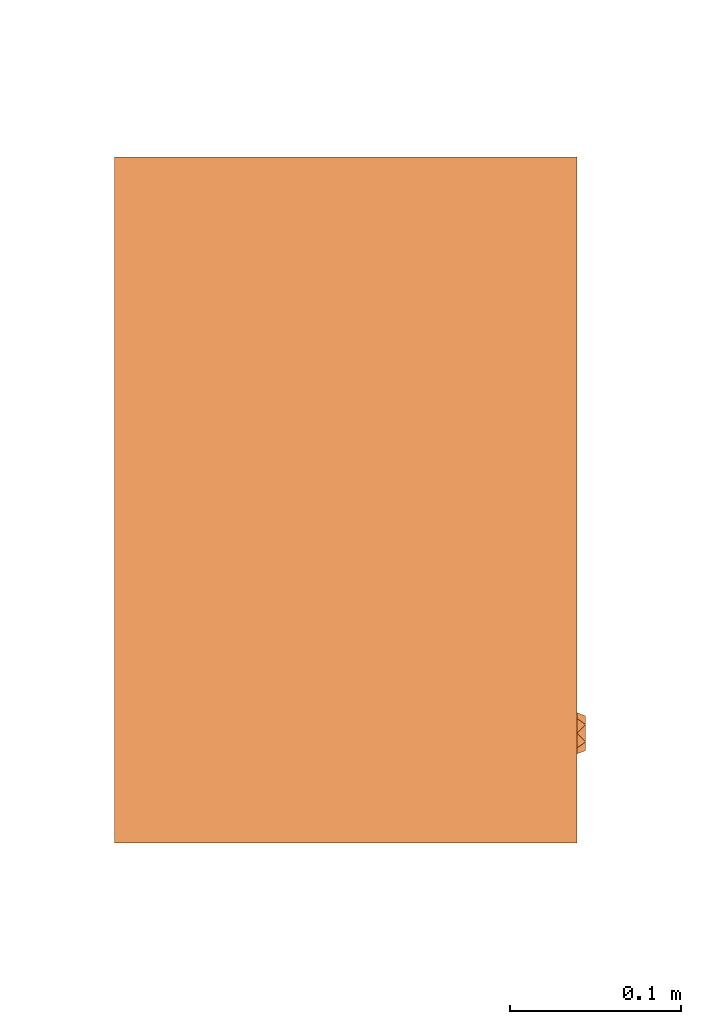
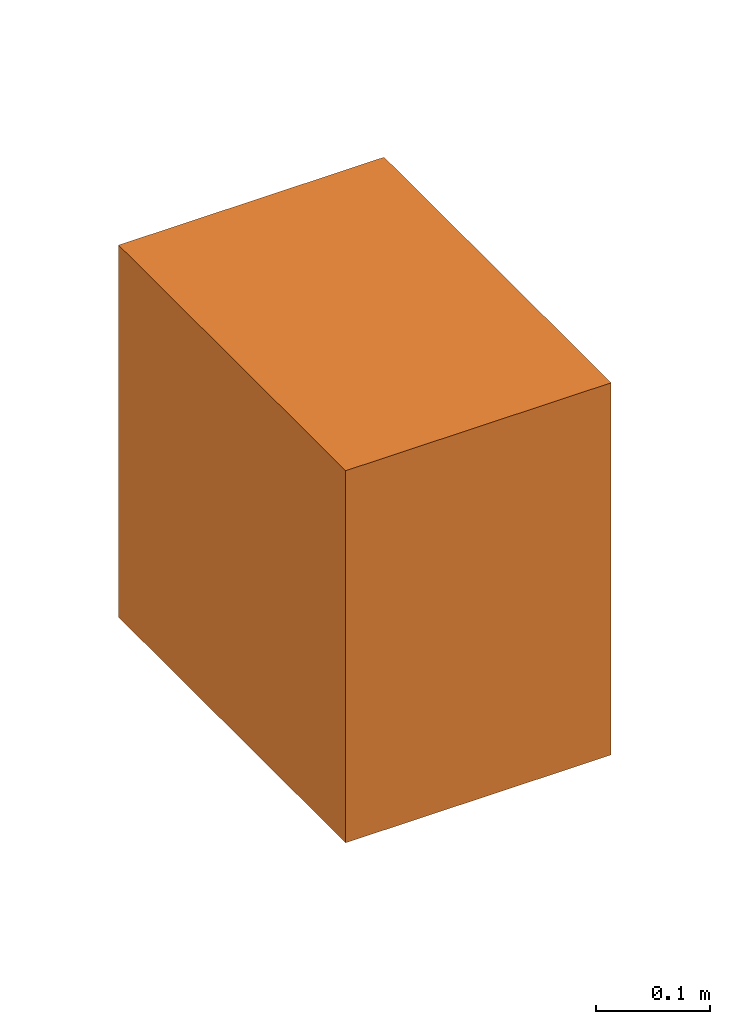
# One storey, part 3 of 3: 1 proxy.
"""IFC2X3 building model written with IfcOpenShell, lengths in millimetres."""

from ifc_helpers import new_model, entity, si_unit, converted_unit, derived_unit, direction, frame, origin, place, context, subcontext, project, spatial, faceted_brep, source, transform, mapped, material, material_list, type_object, type_shapes, element, save


model = new_model("IFC2X3")

# Units and contexts
model_context = context("Model", 3, precision=0.01, world=origin(), true_north=direction((6.12303176911189e-17, 1.0)))
body_context = subcontext(model_context, "Body", "Model", "MODEL_VIEW")
ifc_project = project(units=[si_unit("LENGTHUNIT", "METRE", prefix="MILLI"), si_unit("AREAUNIT", "SQUARE_METRE"), si_unit("VOLUMEUNIT", "CUBIC_METRE"), converted_unit("PLANEANGLEUNIT", "DEGREE", entity("IfcRatioMeasure", 0.0174532925199433), si_unit("PLANEANGLEUNIT", "RADIAN"), dimensions=[0, 0, 0, 0, 0, 0, 0]), si_unit("MASSUNIT", "GRAM", prefix="KILO"), derived_unit("MASSDENSITYUNIT", [(si_unit("MASSUNIT", "GRAM", prefix="KILO"), 1), (si_unit("LENGTHUNIT", "METRE"), -3)]), derived_unit("MOMENTOFINERTIAUNIT", [(si_unit("LENGTHUNIT", "METRE"), 4)]), si_unit("TIMEUNIT", "SECOND"), si_unit("FREQUENCYUNIT", "HERTZ"), si_unit("THERMODYNAMICTEMPERATUREUNIT", "DEGREE_CELSIUS"), derived_unit("THERMALTRANSMITTANCEUNIT", [(si_unit("MASSUNIT", "GRAM", prefix="KILO"), 1), (si_unit("THERMODYNAMICTEMPERATUREUNIT", "KELVIN"), -1), (si_unit("TIMEUNIT", "SECOND"), -3)]), derived_unit("VOLUMETRICFLOWRATEUNIT", [(si_unit("LENGTHUNIT", "METRE"), 3), (si_unit("TIMEUNIT", "SECOND"), -1)]), derived_unit("MASSFLOWRATEUNIT", [(si_unit("MASSUNIT", "GRAM", prefix="KILO"), 1), (si_unit("TIMEUNIT", "SECOND"), -1)]), derived_unit("ROTATIONALFREQUENCYUNIT", [(si_unit("TIMEUNIT", "SECOND"), -1)]), si_unit("ELECTRICCURRENTUNIT", "AMPERE"), si_unit("ELECTRICVOLTAGEUNIT", "VOLT"), si_unit("POWERUNIT", "WATT"), si_unit("FORCEUNIT", "NEWTON", prefix="KILO"), si_unit("ILLUMINANCEUNIT", "LUX"), si_unit("LUMINOUSFLUXUNIT", "LUMEN"), si_unit("LUMINOUSINTENSITYUNIT", "CANDELA"), derived_unit("USERDEFINED", [(si_unit("MASSUNIT", "GRAM", prefix="KILO"), -1), (si_unit("LENGTHUNIT", "METRE"), -2), (si_unit("TIMEUNIT", "SECOND"), 3), (si_unit("LUMINOUSFLUXUNIT", "LUMEN"), 1)]), derived_unit("LINEARVELOCITYUNIT", [(si_unit("LENGTHUNIT", "METRE"), 1), (si_unit("TIMEUNIT", "SECOND"), -1)]), si_unit("PRESSUREUNIT", "PASCAL"), derived_unit("USERDEFINED", [(si_unit("LENGTHUNIT", "METRE"), -2), (si_unit("MASSUNIT", "GRAM", prefix="KILO"), 1), (si_unit("TIMEUNIT", "SECOND"), -2)]), derived_unit("LINEARFORCEUNIT", [(si_unit("MASSUNIT", "GRAM", prefix="KILO"), 1), (si_unit("LENGTHUNIT", "METRE"), 1), (si_unit("TIMEUNIT", "SECOND"), -2), (si_unit("LENGTHUNIT", "METRE"), -1)]), derived_unit("PLANARFORCEUNIT", [(si_unit("MASSUNIT", "GRAM", prefix="KILO"), 1), (si_unit("LENGTHUNIT", "METRE"), 1), (si_unit("TIMEUNIT", "SECOND"), -2), (si_unit("LENGTHUNIT", "METRE"), -2)])], contexts=[model_context])

# Site, building, storey
site_placement = place(None, frame((0.0, 2493.83037508239, 0.0)))
site = spatial("IfcSite", under=ifc_project, at=site_placement, CompositionType="ELEMENT")
building_placement = place(site_placement, origin())
building = spatial("IfcBuilding", under=site, at=building_placement, CompositionType="ELEMENT")
storey_placement = place(building_placement, frame((0.0, 0.0, -4200.0)))
storey = spatial("IfcBuildingStorey", under=building, at=storey_placement, CompositionType="ELEMENT", Elevation=-4200.0)

# Proxy
ifc_material_1 = material()
ifc_material_2 = material(Name="RBZ_")
ifc_material_list = material_list([ifc_material_1, ifc_material_2])
building_element_proxy_type = type_object("IfcBuildingElementProxyType", PredefinedType="NOTDEFINED", material=ifc_material_1)
shared_shape = source(origin(), body_context, "Body", "Brep", [
    faceted_brep([(348.066047820178, 270.0, 184.812766074716), (344.550721329073, 270.0, 176.326017183723), (346.146727645, 275.0, 184.812766074716), (341.10535004154, 275.0, 176.080843925383), (336.06397243808, 270.0, 172.810690692619), (327.577223547088, 270.0, 176.326017183723), (331.02259483462, 275.0, 176.080843925383), (325.98121723116, 275.0, 184.812766074716), (324.061897055983, 270.0, 184.812766074716), (327.577223547088, 270.0, 193.299514965709), (331.02259483462, 275.0, 193.544688224048), (336.06397243808, 270.0, 196.814841456813), (344.550721329073, 270.0, 193.299514965709), (341.10535004154, 275.0, 193.544688224048), (336.06397243808, 270.0, 184.812766074716), (336.063972438081, 275.0, 184.812766074716)], [[[0, 1, 2]], [[3, 2, 1]], [[1, 4, 3]], [[4, 5, 6]], [[5, 7, 6]], [[7, 5, 8]], [[4, 6, 3]], [[8, 9, 7]], [[10, 7, 9]], [[9, 11, 10]], [[11, 12, 13]], [[12, 2, 13]], [[2, 12, 0]], [[11, 13, 10]], [[5, 14, 8]], [[4, 14, 5]], [[4, 1, 14]], [[0, 14, 1]], [[0, 12, 14]], [[11, 14, 12]], [[11, 9, 14]], [[9, 8, 14]], [[6, 7, 15]], [[15, 3, 6]], [[7, 10, 15]], [[13, 15, 10]], [[15, 13, 2]], [[15, 2, 3]]]),
    faceted_brep([(0.0, 270.0, 400.0), (400.0, 270.0, 400.0), (400.0, 270.0, 0.0), (0.0, 270.0, 0.0), (380.0, 270.0, 380.0), (20.0, 270.0, 380.0), (20.0, 270.0, 20.0), (380.0, 270.0, 20.0), (0.0, 0.0, 400.0), (0.0, 0.0, 0.0), (400.0, 0.0, 0.0), (400.0, 0.0, 400.0), (20.0, 260.0, 380.0), (380.0, 260.0, 380.0), (380.0, 260.0, 20.0), (20.0, 260.0, 20.0), (377.5, 260.0, 377.500000000002), (22.4999999999994, 260.0, 377.500000000001), (22.5000000000005, 260.0, 22.5), (377.500000000001, 260.0, 22.5000000000012), (377.5, 270.0, 377.500000000002), (22.4999999999994, 270.0, 377.500000000001), (22.5000000000005, 270.0, 22.5), (377.500000000001, 270.0, 22.5000000000012)], [[[0, 1, 2, 3], [4, 5, 6, 7]], [[8, 9, 10, 11]], [[1, 0, 8, 11]], [[2, 1, 11, 10]], [[3, 2, 10, 9]], [[0, 3, 9, 8]], [[12, 13, 14, 15], [16, 17, 18, 19]], [[13, 12, 5, 4]], [[14, 13, 4, 7]], [[15, 14, 7, 6]], [[12, 15, 6, 5]], [[17, 16, 20, 21]], [[18, 17, 21, 22]], [[19, 18, 22, 23]], [[16, 19, 23, 20]], [[21, 20, 23, 22]]]),
])
type_shapes(building_element_proxy_type, [shared_shape])
proxy_placement = place(storey_placement, frame((68830.1119834161, 5083.66960399955, 1095.0), z_axis=(0.0, 0.0, 1.0), x_axis=(0.0, -1.0, 0.0)))
element("IfcBuildingElementProxy", 1, at=proxy_placement, inside=storey, type_object=building_element_proxy_type, material=ifc_material_list, context=body_context, shape_type="MappedRepresentation", body=[
    mapped(shared_shape, transform((0.0, 0.0, 0.0), scale=1.0)),
])

save(model, "model.ifc")
